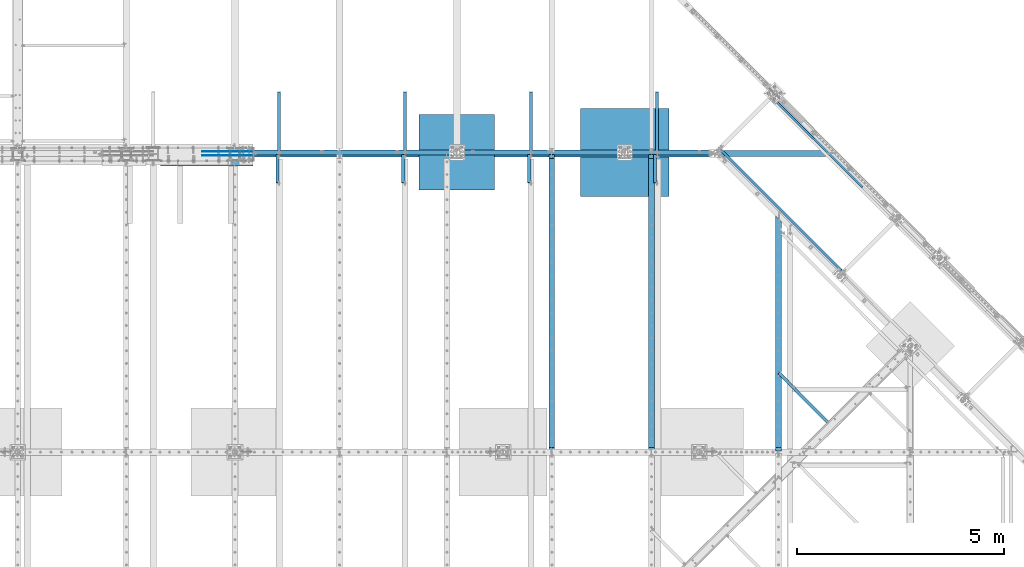
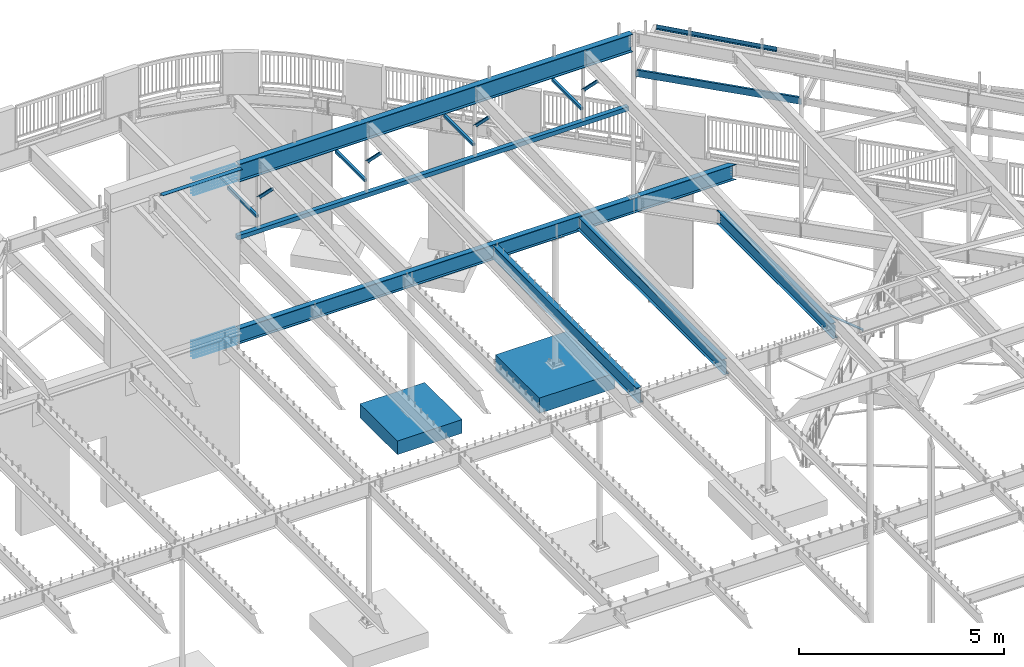
# One storey, part 326 of 975: 37 beams, 4 members.
"""IFC2X3 building model written with IfcOpenShell, lengths in millimetres."""

from ifc_helpers import new_model, si_unit, frame, origin_with_axes, place, context, subcontext, project, spatial, faceted_brep, material, type_object, element, save


model = new_model("IFC2X3")

# Units and contexts
model_context = context("Model", 3, precision=1e-05, world=origin_with_axes())
body_context = subcontext(model_context, "Body", "Model", "MODEL_VIEW")
ifc_project = project(units=[si_unit("LENGTHUNIT", "METRE", prefix="MILLI"), si_unit("AREAUNIT", "SQUARE_METRE"), si_unit("VOLUMEUNIT", "CUBIC_METRE"), si_unit("MASSUNIT", "GRAM", prefix="KILO"), si_unit("TIMEUNIT", "SECOND"), si_unit("PLANEANGLEUNIT", "RADIAN"), si_unit("SOLIDANGLEUNIT", "STERADIAN"), si_unit("THERMODYNAMICTEMPERATUREUNIT", "DEGREE_CELSIUS"), si_unit("LUMINOUSINTENSITYUNIT", "LUMEN")], contexts=[model_context])

# Site, building, storey
site_placement = place(None, origin_with_axes())
site = spatial("IfcSite", under=ifc_project, at=site_placement, CompositionType="ELEMENT")
building_placement = place(site_placement, origin_with_axes())
building = spatial("IfcBuilding", under=site, at=building_placement, Name="Undefined", CompositionType="ELEMENT")
storey_placement = place(building_placement, origin_with_axes())
storey = spatial("IfcBuildingStorey", under=building, at=storey_placement, Name="Undefined", CompositionType="ELEMENT", Elevation=0.0)

# Beams
ifc_material_1 = material(Name="STEEL/A36")
beam_type_1 = type_object("IfcBeamType", Name="L3X3X3/16", PredefinedType="NOTDEFINED")
beam_1_placement = place(storey_placement, frame((26609.1095943262, 15351.2595694684, 3500.82319096542), z_axis=(-0.709201369085879, -0.705005970248986, -3.88708940590731e-11), x_axis=(0.668493859661908, -0.672471979659895, -0.317643504839351)))
element("IfcBeam", 1, at=beam_1_placement, inside=storey, type_object=beam_type_1, material=ifc_material_1, Name="ANGLE", ObjectType="L3X3X3/16", context=body_context, shape_type="Brep", body=[
    faceted_brep([(1805.75505965487, -38.0999848286856, -33.3375000011256), (1805.7550483363, -38.0999874451672, -38.1000000011118), (1805.75504779872, 33.3375083154024, -38.1000000009481), (1805.75505910126, 33.3375121047993, -33.33750000082), (1825.84512851132, -26.6347548695767, -38.1000000010317), (1825.84531068586, -26.6346938414199, -33.3375000011692), (1830.36134276969, -25.1218538821231, 38.0999999983069), (1825.84531068138, -26.6346938276884, 38.0999999987871), (1830.36116117237, -25.1219147321481, -38.1000000011736), (49.1111607979174, -38.0999996707915, -33.3375000000524), (49.1111494785901, -38.0999996707933, -38.1000000000531), (1754.34679386706, -38.0999882398091, -38.1000000008753), (1754.34679386708, -38.0999882398073, -33.3375000008782), (49.1111489563682, 38.1000003292011, -38.0999999999622), (49.1111603083318, 33.3375003292022, -33.3374999999724), (49.1113300982161, 33.3375003292231, 38.0999999999876), (49.1113300655752, 38.100000329222, 38.0999999999949), (1809.18227678388, 38.100012127793, 38.0999999991473), (1809.18227678352, 38.100012127773, -38.1000000008098), (1805.75505910161, 33.3375121048202, 38.0999999991363)], [[[0, 1, 2, 3]], [[3, 2, 4, 5]], [[6, 7, 5, 4, 8]], [[9, 10, 11, 12]], [[13, 10, 9, 14, 15, 16]], [[13, 16, 17, 18]], [[18, 17, 6, 8]], [[2, 1, 11, 10, 13, 18, 8, 4]], [[12, 11, 1, 0]], [[14, 9, 12, 0, 3]], [[15, 14, 3, 19]], [[19, 3, 5, 7]], [[17, 16, 15, 19, 7, 6]]]),
])
beam_type_2 = type_object("IfcBeamType", Name="C8X11.5", PredefinedType="NOTDEFINED")
beam_2_placement = place(storey_placement, frame((25217.6926586422, 20740.4198954888, 7518.41643900487), z_axis=(-0.0127173168834997, 0.0127218758834606, -0.999838198772827), x_axis=(0.706865667090082, -0.707119051090114, -0.0179882260022924)))
element("IfcBeam", 2, at=beam_2_placement, inside=storey, type_object=beam_type_2, material=ifc_material_1, Name="BEAM", ObjectType="C8X11.5", context=body_context, shape_type="Brep", body=[
    faceted_brep([(25.0273563885617, 22.2249999999331, -76.2000000000671), (25.035636834773, 28.5749999999243, -76.2000000000744), (49.9041381300881, 28.5749999999498, -76.1999999999989), (49.9041381300995, 22.2249999999585, -76.2000000000016), (54.7642176481299, 28.5749999999571, -77.1667299225792), (54.7642176481413, 22.2249999999585, -77.166729922581), (58.8843941162781, 28.5749999999607, -79.9197438230522), (58.8843941162891, 22.2249999999622, -79.9197438230531), (61.6374080167493, 28.5749999999534, -84.0399202912031), (61.637408016762, 22.2249999999622, -84.0399202912049), (62.6041379393469, 19.0576241938725, -88.8999998092504), (62.6041379393328, 28.5749999999534, -88.8999998092477), (62.6041379393218, 28.5749999999425, -101.599999999954), (62.6041379393819, -28.5750000000044, -101.599999999935), (62.6041379393869, -28.5750000000007, -96.8355949999368), (62.4991749046949, 22.2249999999549, -88.3723149999569), (4164.10940048445, -28.5749999955915, -96.8355949983479), (4164.10940048445, -28.5749999955951, -101.599999998347), (4164.10940048439, 28.5750000043518, -101.599999998366), (4164.10940048435, 28.5750000043627, -88.8999998015706), (4164.10940048437, 19.0576242348288, -88.8999998015724), (28.2344609917245, 28.575000000099, 101.599999999969), (28.1599369758496, -28.5749999998516, 101.599999999989), (4214.8435793051, -28.5749999953478, 101.600000001609), (4214.90940048472, 28.5750000045955, 101.600000001591), (28.0742199128135, -28.5749999998552, 96.8355949999905), (4214.75786224206, -28.5749999953514, 96.8355950016112), (27.9881994526113, 22.2250000000859, 88.3723149999751), (4214.66410592741, 22.2250000045897, 88.3723150015967), (4211.70326286347, 22.2250000044332, -76.1999999922791), (4211.71057632787, 28.5750000044281, -76.1999999922855), (4176.80940029361, 22.2250000043896, -76.1999999923137), (4176.8094002936, 28.5750000043881, -76.1999999923128), (4171.94932077558, 22.2250000043859, -77.1667299149076), (4171.94932077557, 28.5750000043809, -77.1667299149067), (4167.82914430743, 22.2250000043787, -79.919743815386), (4167.82914430742, 28.5750000043736, -79.9197438153842), (4165.07613040695, 22.225000004375, -84.0399202835351), (4165.07613040694, 28.5750000043663, -84.0399202835333), (4164.21436351786, 22.2250000043678, -88.3723149983689)], [[[0, 1, 2, 3]], [[3, 2, 4, 5]], [[5, 4, 6, 7]], [[7, 6, 8, 9]], [[10, 11, 12, 13, 14]], [[15, 9, 8, 11, 10]], [[16, 17, 18, 19, 20]], [[21, 22, 23, 24]], [[22, 25, 26, 23]], [[25, 27, 28, 26]], [[24, 23, 26, 28, 29, 30]], [[29, 31, 32, 30]], [[33, 34, 32, 31]], [[35, 36, 34, 33]], [[37, 38, 36, 35]], [[39, 20, 19, 38, 37]], [[14, 16, 20, 39, 15, 10]], [[17, 16, 14, 13]], [[18, 17, 13, 12]], [[6, 4, 2, 1, 21, 24, 30, 32, 34, 36, 38, 19, 18, 12, 11, 8]], [[27, 25, 22, 21, 1, 0]], [[39, 37, 35, 33, 31, 29, 28, 27, 0, 3, 5, 7, 9, 15]]]),
])
beam_type_3 = type_object("IfcBeamType", PredefinedType="NOTDEFINED")
beam_3_placement = place(storey_placement, frame((27578.1189529659, 20861.2740185157, 7561.50945801746), z_axis=(0.707357212670032, -0.705780872372475, -0.0389760680011505), x_axis=(0.706317571755026, 0.707895110754471, 0.0)))
element("IfcBeam", 3, at=beam_3_placement, inside=storey, type_object=beam_type_3, material=ifc_material_1, Name="DECK_EDGE", context=body_context, shape_type="Brep", body=[
    faceted_brep([(-1.44573277793825e-08, -3.17500000027667, -1523.99999999641), (7.79618858359754e-09, -3.17499999972461, 1523.99999999641), (1.44573277793825e-08, 3.17500000027576, 1523.99999999641), (-7.79255060479045e-09, 3.17499999972188, -1523.9999999964), (51.3282235099323, 3.17500000138443, 1523.99999999883), (51.3282235078514, 3.17500000009932, -1523.99999999884), (57.6782232685582, -3.17499999981101, -1523.99999999882), (57.6782232706391, -3.17499999852589, 1523.99999999885), (51.3282275774545, 111.125003231497, 1523.99999999851), (51.3282275765887, 111.125003228997, -1523.99999999916), (57.6782275774676, 111.125002992181, 1523.99999999851), (57.6782275766018, 111.125002989683, -1523.99999999917)], [[[0, 1, 2, 3]], [[3, 2, 4, 5]], [[1, 0, 6, 7]], [[5, 4, 8, 9]], [[4, 2, 1, 7, 10, 8]], [[7, 6, 11, 10]], [[6, 0, 3, 5, 9, 11]], [[10, 11, 9, 8]]]),
])

# Members
member_type = type_object("IfcMemberType", Name="L3X3X3/8", PredefinedType="NOTDEFINED")
for number, where, z_axis, x_axis, name in (
    (4, (23658.5125015259, 19845.7293456865, 8357.14081169942), (0.0, -0.707106781186538, -0.707106781186557), (0.0, 0.707106781186529, -0.707106781186566), "ANGLE"),
    (5, (20610.5125015259, 19845.7293456865, 8357.14081169942), (0.0, -0.707106781186538, -0.707106781186557), (0.0, 0.707106781186529, -0.707106781186566), "ANGLE"),
    (6, (17562.5125015259, 19845.7293456865, 8357.14081169942), (0.0, -0.707106781186538, -0.707106781186557), (0.0, 0.707106781186529, -0.707106781186566), "ANGLE"),
    (7, (14514.5125015259, 19845.7293458214, 8357.14081183843), (0.0, -0.707106781186538, -0.707106781186557), (0.0, 0.707106781186529, -0.707106781186566), "ANGLE"),
):
    element("IfcMember", number, at=place(storey_placement, frame(where, z_axis=z_axis, x_axis=x_axis)), inside=storey, type_object=member_type, material=ifc_material_1, Name=name, ObjectType="L3X3X3/8", context=body_context, shape_type="Brep", body=[
        faceted_brep([(58.1980091705109, 38.0999999999985, -38.0999999999949), (58.1980092243903, 38.0999999999985, 38.1000000000204), (1023.10542864106, 38.0999999999985, 38.1000000003223), (1023.10542858717, 38.0999999999985, -38.0999999996893), (58.1980092243903, 28.5750000000007, 38.1000000000204), (1023.10542864106, 28.5750000000007, 38.1000000003223), (58.1980091772448, 28.5750000000007, -28.5749999999935), (1023.10542859391, 28.5750000000007, -28.5749999996879), (58.1980091772448, -38.0999999999985, -28.5749999999935), (1023.10542859391, -38.0999999999985, -28.5749999996879), (58.1980091705109, -38.0999999999985, -38.0999999999949), (1023.10542858717, -38.0999999999985, -38.0999999996893)], [[[0, 1, 2, 3]], [[1, 4, 5, 2]], [[4, 6, 7, 5]], [[6, 8, 9, 7]], [[8, 10, 11, 9]], [[10, 0, 3, 11]], [[5, 7, 9, 11, 3, 2]], [[10, 8, 6, 4, 1, 0]]]),
    ])

# Beams
beam_type_4 = type_object("IfcBeamType", Name="L5X3X5/16", PredefinedType="NOTDEFINED")
beam_4_placement = place(storey_placement, frame((11687.1750001999, 20380.3249929427, 8801.1), z_axis=(0.0, -1.0, 0.0), x_axis=(1.0, 0.0, 0.0)))
element("IfcBeam", 8, at=beam_4_placement, inside=storey, type_object=beam_type_4, material=ifc_material_1, Name="LEDGER_ANGLE", ObjectType="L5X3X5/16", context=body_context, shape_type="Brep", body=[
    faceted_brep([(5.0931703299284e-11, 38.0999999999999, -63.5000000000255), (-4.72937244921923e-11, 38.0999999999999, 63.5000000000182), (2241.54999999997, 38.1000000000004, 63.4999999970132), (2241.55000000003, 38.1000000000004, -63.5000000029868), (-3.63797880709171e-12, 30.1625000000404, 63.4999999999909), (2241.54999999997, 30.1625000000004, 63.4999999970132), (3.41060513164848e-12, 30.1624999999367, -55.5625000000091), (2241.55000000003, 30.1625000000004, -55.5625000029868), (2.27373675443232e-12, -38.1000000000313, -55.5624999999873), (2241.55000000003, -38.1000000000004, -55.5625000029868), (5.0931703299284e-11, -38.0999999999999, -63.5000000000255), (2241.55000000003, -38.1000000000004, -63.5000000029868)], [[[0, 1, 2, 3]], [[1, 4, 5, 2]], [[4, 6, 7, 5]], [[6, 8, 9, 7]], [[8, 10, 11, 9]], [[10, 0, 3, 11]], [[5, 7, 9, 11, 3, 2]], [[10, 8, 6, 4, 1, 0]]]),
])
ifc_material_2 = material(Name="STEEL/A496")
beam_type_5 = type_object("IfcBeamType", Name="#6 DBA", PredefinedType="NOTDEFINED")
for number, where, z_axis, x_axis, name in (
    (9, (13909.6749905832, 20570.8250016075, 8618.54742537138), (0.0, 1.0, 0.0), (-0.999999999999998, 6.90000001668524e-08, 0.0), "ROD"),
    (10, (13909.6749909893, 20672.4250015897, 8529.64743747955), (0.0, 1.0, 0.0), (-0.999999999999998, 6.90000001668524e-08, 0.0), "ROD"),
    (11, (13909.6749905832, 20570.8250015897, 8529.64743749572), (0.0, 1.0, 0.0), (-0.999999999999998, 6.90000001668524e-08, 0.0), "ROD"),
    (12, (13909.6749909893, 20672.4250015719, 8440.74744960389), (0.0, 1.0, 0.0), (-0.999999999999998, 6.90000001668524e-08, 0.0), "ROD"),
    (13, (13909.6749905832, 20570.8250015719, 8440.74744962006), (0.0, 1.0, 0.0), (-0.999999999999998, 6.90000001668524e-08, 0.0), "ROD"),
    (14, (13909.6749909893, 20672.425001554, 8351.84746172823), (0.0, 1.0, 0.0), (-0.999999999999998, 6.90000001668524e-08, 0.0), "ROD"),
    (15, (13909.6749905832, 20570.825001554, 8351.8474617444), (0.0, 1.0, 0.0), (-0.999999999999998, 6.90000001668524e-08, 0.0), "ROD"),
    (16, (13909.6749909893, 20672.4250016431, 8796.34740110652), (0.0, 1.0, 0.0), (-0.999999999999998, 6.90000001668524e-08, 0.0), "ROD"),
    (17, (13909.6749905832, 20570.8250016431, 8796.34740112269), (0.0, 1.0, 0.0), (-0.999999999999998, 6.90000001668524e-08, 0.0), "ROD"),
    (18, (13909.675, 20672.5350997173, 3849.6875), (0.0, 1.0, 0.0), (-0.999999999999998, 6.90000001668524e-08, 0.0), "ROD"),
    (19, (13909.675, 20570.9350997173, 3849.6875), (0.0, 1.0, 0.0), (-0.999999999999998, 6.90000001668524e-08, 0.0), "ROD"),
    (20, (13909.675, 20672.5350997173, 3760.7875), (0.0, 1.0, 0.0), (-0.999999999999998, 6.90000001668524e-08, 0.0), "ROD"),
    (21, (13909.675, 20570.9350997173, 3760.7875), (0.0, 1.0, 0.0), (-0.999999999999998, 6.90000001668524e-08, 0.0), "ROD"),
    (22, (13909.675, 20672.5350997173, 3671.8875), (0.0, 1.0, 0.0), (-0.999999999999998, 6.90000001668524e-08, 0.0), "ROD"),
    (23, (13909.675, 20570.9350997173, 3671.8875), (0.0, 1.0, 0.0), (-0.999999999999998, 6.90000001668524e-08, 0.0), "ROD"),
    (24, (13909.675, 20672.5350997173, 3582.9875), (0.0, 1.0, 0.0), (-0.999999999999998, 6.90000001668524e-08, 0.0), "ROD"),
    (25, (13909.675, 20570.9350997173, 3582.9875), (0.0, 1.0, 0.0), (-0.999999999999998, 6.90000001668524e-08, 0.0), "ROD"),
    (26, (13909.675, 20672.5350997173, 3494.0875), (0.0, 1.0, 0.0), (-0.999999999999998, 6.90000001668524e-08, 0.0), "ROD"),
    (27, (13909.675, 20570.9350997173, 3494.0875), (0.0, 1.0, 0.0), (-0.999999999999998, 6.90000001668524e-08, 0.0), "ROD"),
    (28, (13909.675, 20672.5350997173, 3938.5875), (0.0, 1.0, 0.0), (-0.999999999999998, 6.90000001668524e-08, 0.0), "ROD"),
    (29, (13909.675, 20570.9350997173, 3938.5875), (0.0, 1.0, 0.0), (-0.999999999999998, 6.90000001668524e-08, 0.0), "ROD"),
):
    element("IfcBeam", number, at=place(storey_placement, frame(where, z_axis=z_axis, x_axis=x_axis)), inside=storey, type_object=beam_type_5, material=ifc_material_2, Name=name, ObjectType="#6 DBA", context=body_context, shape_type="Brep", body=[
        faceted_brep([(0.0, -6.34999999998763, -3.63797880709171e-12), (0.0, -4.49012806052269, -4.49012806054634), (1219.19983372321, -4.49012806053543, -4.49012805836537), (1219.19983372321, -6.35000000000036, 2.16823536902666e-09), (0.0, 7.27595761418343e-12, -6.35000000000764), (1219.19983372321, 0.0, -6.34999999783395), (0.0, 4.49012806053724, -4.49012806053906), (1219.19983372321, 4.49012806053543, -4.49012805836537), (0.0, 6.34999999999491, 5.45696821063757e-12), (1219.19983372321, 6.35000000000036, 2.16823536902666e-09), (0.0, 4.49012806052633, 4.49012806054634), (1219.19983372321, 4.49012806053543, 4.49012806270184), (0.0, 0.0, 6.35000000000764), (1219.19983372321, 0.0, 6.35000000216678), (0.0, -4.49012806053361, 4.49012806053543), (1219.19983372321, -4.49012806053543, 4.49012806270184)], [[[0, 1, 2, 3]], [[1, 4, 5, 2]], [[4, 6, 7, 5]], [[6, 8, 9, 7]], [[8, 10, 11, 9]], [[10, 12, 13, 11]], [[12, 14, 15, 13]], [[14, 0, 3, 15]], [[5, 7, 9, 11, 13, 15, 3, 2]], [[14, 12, 10, 8, 6, 4, 1, 0]]]),
    ])
ifc_material_3 = material()
beam_type_6 = type_object("IfcBeamType", Name="HSS5X5X3/8", PredefinedType="NOTDEFINED")
beam_5_placement = place(storey_placement, frame((13928.725, 20646.9149014879, 6623.05), z_axis=(0.0, 0.0, -1.0), x_axis=(1.0, 0.0, 0.0)))
element("IfcBeam", 30, at=beam_5_placement, inside=storey, type_object=beam_type_6, material=ifc_material_3, Name="FRAME", ObjectType="HSS5X5X3/8", context=body_context, shape_type="Brep", body=[
    faceted_brep([(19.0499999999975, 53.9749999999985, -53.9750000000004), (19.0499999999975, -53.9749999999985, -53.9750000000004), (11028.4222488598, -53.9749999999985, -53.9750000000004), (11028.4222488598, 53.9749999999985, -53.9750000000004), (19.0499999999975, -53.9749999999985, 53.9750000000004), (11028.4222488598, -53.9749999999985, 53.9750000000004), (19.0499999999975, 53.9749999999985, 53.9750000000004), (11028.4222488598, 53.9749999999985, 53.9750000000004), (19.0499999999975, 63.5, -63.5), (19.0499999999975, 63.5, 63.5), (11028.4222488598, 63.5, 63.5), (11028.4222488598, 63.5, -63.5), (19.0499999999975, -63.5, 63.5), (11028.4222488598, -63.5, 63.5), (19.0499999999975, -63.5, -63.5), (11028.4222488598, -63.5, -63.5)], [[[0, 1, 2, 3]], [[1, 4, 5, 2]], [[4, 6, 7, 5]], [[6, 0, 3, 7]], [[8, 9, 10, 11]], [[9, 12, 13, 10]], [[12, 14, 15, 13]], [[14, 8, 11, 15]], [[13, 15, 11, 10], [5, 7, 3, 2]], [[14, 12, 9, 8], [6, 4, 1, 0]]]),
])
ifc_material_4 = material(Name="STEEL/A992")
beam_type_7 = type_object("IfcBeamType", Name="W18X40", PredefinedType="NOTDEFINED")
beam_6_placement = place(storey_placement, frame((13928.725, 20621.7350997173, 3709.9875), z_axis=(0.0, 0.0, 1.0), x_axis=(1.0, 0.0, 0.0)))
element("IfcBeam", 31, at=beam_6_placement, inside=storey, type_object=beam_type_7, material=ifc_material_4, Name="BEAM", ObjectType="W18X40", context=body_context, shape_type="Brep", body=[
    faceted_brep([(25.3999999999992, -76.1999999999998, -214.3125), (25.3999999999996, -76.2000000000007, -227.0125), (14043.6465678821, -76.2000000000007, -227.0125), (14043.6465678821, -76.2000000000007, -214.3125), (25.3999999999992, -3.96875, -214.3125), (13971.4153178821, -3.96875, -214.3125), (25.3999999999992, -3.96875, 214.312499999999), (13971.4153178821, -3.96875, 214.3125), (25.3999999999992, -76.1999999999998, 214.312499999999), (14043.6465678821, -76.2000000000007, 214.3125), (25.3999999999996, -76.2000000000007, 227.0125), (14043.6465678821, -76.2000000000007, 227.0125), (25.3999999999996, 76.2000000000007, 227.0125), (13891.2465678821, 76.2000000000007, 227.0125), (25.3999999999992, 76.1999999999998, 214.312499999999), (13891.2465678821, 76.2000000000007, 214.3125), (25.3999999999992, 3.96875, 214.312499999999), (13963.4778178821, 3.96875, 214.3125), (25.3999999999992, 3.96875, -214.3125), (13963.4778178821, 3.96875, -214.3125), (25.3999999999992, 76.1999999999998, -214.3125), (13891.2465678821, 76.2000000000007, -214.3125), (25.3999999999996, 76.2000000000007, -227.0125), (13891.2465678821, 76.2000000000007, -227.0125)], [[[0, 1, 2, 3]], [[4, 0, 3, 5]], [[6, 4, 5, 7]], [[8, 6, 7, 9]], [[10, 8, 9, 11]], [[12, 10, 11, 13]], [[14, 12, 13, 15]], [[16, 14, 15, 17]], [[18, 16, 17, 19]], [[20, 18, 19, 21]], [[1, 0, 4, 6, 8, 10, 12, 14, 16, 18, 20, 22]], [[1, 22, 23, 2]], [[19, 17, 15, 13, 11, 9, 7, 5, 3, 2, 23, 21]], [[22, 20, 21, 23]]]),
])
beam_type_8 = type_object("IfcBeamType", Name="HSS3X3X1/4", PredefinedType="NOTDEFINED")
for number, where, z_axis, x_axis in (
    (32, (23701.375, 20647.0249996575, 6997.7), (0.0, 0.0, -1.0), (0.0, 1.0, 0.0)),
    (33, (20653.375, 20647.025, 6997.7), (0.0, 0.0, -1.0), (0.0, 1.0, 0.0)),
    (34, (17605.375, 20647.025, 6997.7), (0.0, 0.0, -1.0), (0.0, 1.0, 0.0)),
    (35, (14557.375, 20646.9149014879, 6997.7), (0.0, 0.0, -1.0), (0.0, 1.0, 0.0)),
):
    element("IfcBeam", number, at=place(storey_placement, frame(where, z_axis=z_axis, x_axis=x_axis)), inside=storey, type_object=beam_type_8, material=ifc_material_3, ObjectType="HSS3X3X1/4", context=body_context, shape_type="Brep", body=[
        faceted_brep([(38.1000000984241, 31.75, -31.75), (38.1000000984241, -31.75, -31.75), (1466.84999999999, -31.75, -31.75), (1466.84999999999, 31.75, -31.75), (38.1000001619213, -31.75, 31.75), (1466.84999999999, -31.75, 31.75), (38.1000001619213, 31.75, 31.75), (1466.84999999999, 31.75, 31.75), (38.1000000920722, 38.0999999999985, -38.1000000000004), (38.1000001682733, 38.0999999999985, 38.1000000000004), (1466.84999999999, 38.1000000000004, 38.1000000000004), (1466.84999999999, 38.1000000000004, -38.1000000000004), (38.1000001682733, -38.0999999999985, 38.1000000000004), (1466.84999999999, -38.1000000000004, 38.1000000000004), (38.1000000920722, -38.0999999999985, -38.1000000000004), (1466.84999999999, -38.1000000000004, -38.1000000000004)], [[[0, 1, 2, 3]], [[1, 4, 5, 2]], [[4, 6, 7, 5]], [[6, 0, 3, 7]], [[8, 9, 10, 11]], [[9, 12, 13, 10]], [[12, 14, 15, 13]], [[14, 8, 11, 15]], [[13, 15, 11, 10], [5, 7, 3, 2]], [[14, 12, 9, 8], [6, 4, 1, 0]]]),
    ])
beam_type_9 = type_object("IfcBeamType", Name="W16X26", PredefinedType="NOTDEFINED")
beam_7_placement = place(storey_placement, frame((26644.6, 13392.15, 3736.975), z_axis=(0.0, 0.0, 1.0), x_axis=(0.0, 1.0, 0.0)))
element("IfcBeam", 36, at=beam_7_placement, inside=storey, type_object=beam_type_9, material=ifc_material_4, Name="BEAM", ObjectType="W16X26", context=body_context, shape_type="Brep", body=[
    faceted_brep([(105.568750190729, -3.17499999999927, 174.625), (105.568750190729, 3.17499999999927, 174.625), (29.368749999996, 3.17499999999927, 174.625), (29.368749999996, -3.17499999999927, 174.625), (110.428829708775, -3.17499999999927, 175.591729922588), (110.428829708775, 3.17499999999927, 175.591729922588), (114.549006176929, -3.17499999999927, 178.344743823066), (114.549006176929, 3.17499999999927, 178.344743823066), (117.302020077406, -3.17499999999927, 182.46492029122), (117.302020077406, 3.17499999999927, 182.46492029122), (118.268749999994, -3.17499999999927, 187.324999809266), (118.268749999994, 3.17499999999927, 187.324999809266), (118.268749999994, -69.8499999999985, 200.024999810586), (118.268749999994, 69.8499999999985, 200.025), (118.268749999994, 69.8499999999985, 190.5), (118.268749999994, 3.17499999999927, 190.5), (118.268749999994, -3.17499999999927, 190.5), (118.268749999994, -69.8499999999985, 190.5), (29.368749999996, -3.17499999999927, -190.5), (29.368749999996, -69.8499999999985, -190.5), (5582.0400360495, -69.8499999999985, -190.5), (5649.11146855339, -3.17499999999927, -190.5), (29.368749999996, -69.8499999999985, -200.025), (5582.0400360495, -69.8499999999985, -200.025), (29.368749999996, 69.8499999999985, -200.025), (5722.57065653385, 69.8499999999985, -200.025), (29.368749999996, 69.8499999999985, -190.5), (29.368749999996, 3.17499999999927, -190.5), (5655.49922402995, 3.17499999999927, -190.5), (5722.57065653385, 69.8499999999985, -190.5), (5655.49922402995, 3.17499999999927, 190.5), (5722.57065653385, 69.8499999999985, 190.5), (5722.57065653385, 69.8499999999985, 200.025), (5582.0400360495, -69.8499999999985, 200.025), (5582.0400360495, -69.8499999999985, 190.5), (5649.11146855339, -3.17499999999927, 190.5)], [[[0, 1, 2, 3]], [[4, 5, 1, 0]], [[6, 7, 5, 4]], [[8, 9, 7, 6]], [[10, 11, 9, 8]], [[12, 13, 14, 15, 11, 10, 16, 17]], [[18, 19, 20, 21]], [[19, 22, 23, 20]], [[22, 24, 25, 23]], [[26, 27, 28, 29]], [[24, 26, 29, 25]], [[28, 30, 31, 32, 33, 34, 35, 21, 20, 23, 25, 29]], [[34, 33, 12, 17]], [[35, 34, 17, 16]], [[8, 6, 4, 0, 3, 18, 21, 35, 16, 10]], [[27, 26, 24, 22, 19, 18, 3, 2]], [[30, 28, 27, 2, 1, 5, 7, 9, 11, 15]], [[31, 30, 15, 14]], [[32, 31, 14, 13]], [[33, 32, 13, 12]]]),
])
beam_8_placement = place(storey_placement, frame((23571.2, 13392.15, 3736.975), z_axis=(0.0, 0.0, 1.0), x_axis=(0.0, 1.0, 0.0)))
element("IfcBeam", 37, at=beam_8_placement, inside=storey, type_object=beam_type_9, material=ifc_material_4, Name="BEAM", ObjectType="W16X26", context=body_context, shape_type="Brep", body=[
    faceted_brep([(105.568750190729, -3.17499999999927, 174.625), (105.568750190729, 3.17499999999927, 174.625), (29.368749999996, 3.17499999999927, 174.625), (29.368749999996, -3.17499999999927, 174.625), (110.428829708775, -3.17499999999927, 175.591729922588), (110.428829708775, 3.17499999999927, 175.591729922588), (114.549006176929, -3.17499999999927, 178.344743823066), (114.549006176929, 3.17499999999927, 178.344743823066), (117.302020077406, -3.17499999999927, 182.46492029122), (117.302020077406, 3.17499999999927, 182.46492029122), (118.268749999994, -3.17499999999927, 187.324999809266), (118.268749999994, 3.17499999999927, 187.324999809266), (118.268749999994, -69.8499999999985, 200.024999810586), (118.268749999994, 69.8499999999985, 200.025), (118.268749999994, 69.8499999999985, 190.5), (118.268749999994, 3.17499999999927, 190.5), (118.268749999994, -3.17499999999927, 190.5), (118.268749999994, -69.8499999999985, 190.5), (29.368749999996, -3.17499999999927, -190.5), (29.368749999996, -69.8499999999985, -190.5), (7200.21634971727, -69.8499999999985, -190.5), (7200.21634971727, -3.17499999999927, -190.5), (29.368749999996, -69.8499999999985, -200.025), (7200.21634971727, -69.8499999999985, -200.025), (29.368749999996, 69.8499999999985, -200.025), (7200.21634971727, 69.8499999999985, -200.025), (29.368749999996, 69.8499999999985, -190.5), (7200.21634971727, 69.8499999999985, -190.5), (29.368749999996, 3.17499999999927, -190.5), (7200.21634971727, 3.17499999999927, -190.5), (7200.21634971727, 3.17499999999927, 174.625), (7200.21634971727, -3.17499999999927, 174.625), (7124.01634952653, 3.17499999999927, 174.625), (7124.01634952653, -3.17499999999927, 174.625), (7119.15627000848, 3.17499999999927, 175.591729922588), (7119.15627000848, -3.17499999999927, 175.591729922588), (7115.03609354033, 3.17499999999927, 178.344743823066), (7115.03609354033, -3.17499999999927, 178.344743823066), (7112.28307963985, 3.17499999999927, 182.464920291219), (7112.28307963985, -3.17499999999927, 182.464920291219), (7111.31634971726, 3.17499999999927, 187.324999809265), (7111.31634971726, -3.17499999999927, 187.324999809265), (7111.31634971726, -69.8499999999985, 200.025), (7111.31634971726, -69.8499999999985, 190.5), (7111.31634971726, -3.17499999999927, 190.5), (7111.31634971726, 3.17499999999927, 190.5), (7111.31634971726, 69.8499999999985, 190.5), (7111.31634971726, 69.8499999999985, 200.025)], [[[0, 1, 2, 3]], [[4, 5, 1, 0]], [[6, 7, 5, 4]], [[8, 9, 7, 6]], [[10, 11, 9, 8]], [[12, 13, 14, 15, 11, 10, 16, 17]], [[18, 19, 20, 21]], [[19, 22, 23, 20]], [[22, 24, 25, 23]], [[24, 26, 27, 25]], [[26, 28, 29, 27]], [[21, 20, 23, 25, 27, 29, 30, 31]], [[31, 30, 32, 33]], [[33, 32, 34, 35]], [[35, 34, 36, 37]], [[37, 36, 38, 39]], [[39, 38, 40, 41]], [[42, 43, 44, 41, 40, 45, 46, 47]], [[43, 42, 12, 17]], [[44, 43, 17, 16]], [[8, 6, 4, 0, 3, 18, 21, 31, 33, 35, 37, 39, 41, 44, 16, 10]], [[28, 26, 24, 22, 19, 18, 3, 2]], [[45, 40, 38, 36, 34, 32, 30, 29, 28, 2, 1, 5, 7, 9, 11, 15]], [[46, 45, 15, 14]], [[47, 46, 14, 13]], [[42, 47, 13, 12]]]),
])
beam_9_placement = place(storey_placement, frame((21158.2, 13392.15, 3736.975), z_axis=(0.0, 0.0, 1.0), x_axis=(0.0, 1.0, 0.0)))
element("IfcBeam", 38, at=beam_9_placement, inside=storey, type_object=beam_type_9, material=ifc_material_4, Name="BEAM", ObjectType="W16X26", context=body_context, shape_type="Brep", body=[
    faceted_brep([(105.568750190729, -3.17499999999927, 174.625), (105.568750190729, 3.17499999999927, 174.625), (29.368749999996, 3.17499999999927, 174.625), (29.368749999996, -3.17499999999927, 174.625), (110.428829708775, -3.17499999999927, 175.591729922588), (110.428829708775, 3.17499999999927, 175.591729922588), (114.549006176929, -3.17499999999927, 178.344743823066), (114.549006176929, 3.17499999999927, 178.344743823066), (117.302020077406, -3.17499999999927, 182.46492029122), (117.302020077406, 3.17499999999927, 182.46492029122), (118.268749999994, -3.17499999999927, 187.324999809266), (118.268749999994, 3.17499999999927, 187.324999809266), (118.268749999994, -69.8499999999985, 200.024999810586), (118.268749999994, 69.8499999999985, 200.025), (118.268749999994, 69.8499999999985, 190.5), (118.268749999994, 3.17499999999927, 190.5), (118.268749999994, -3.17499999999927, 190.5), (118.268749999994, -69.8499999999985, 190.5), (29.368749999996, -3.17499999999927, -190.5), (29.368749999996, -69.8499999999985, -190.5), (7200.21634971727, -69.8499999999985, -190.5), (7200.21634971727, -3.17499999999927, -190.5), (29.368749999996, -69.8499999999985, -200.025), (7200.21634971727, -69.8499999999985, -200.025), (29.368749999996, 69.8499999999985, -200.025), (7200.21634971727, 69.8499999999985, -200.025), (29.368749999996, 69.8499999999985, -190.5), (7200.21634971727, 69.8499999999985, -190.5), (29.368749999996, 3.17499999999927, -190.5), (7200.21634971727, 3.17499999999927, -190.5), (7200.21634971727, 3.17499999999927, 174.625), (7200.21634971727, -3.17499999999927, 174.625), (7124.01634952653, 3.17499999999927, 174.625), (7124.01634952653, -3.17499999999927, 174.625), (7119.15627000848, 3.17499999999927, 175.591729922588), (7119.15627000848, -3.17499999999927, 175.591729922588), (7115.03609354033, 3.17499999999927, 178.344743823066), (7115.03609354033, -3.17499999999927, 178.344743823066), (7112.28307963985, 3.17499999999927, 182.464920291219), (7112.28307963985, -3.17499999999927, 182.464920291219), (7111.31634971726, 3.17499999999927, 187.324999809265), (7111.31634971726, -3.17499999999927, 187.324999809265), (7111.31634971726, -69.8499999999985, 200.025), (7111.31634971726, -69.8499999999985, 190.5), (7111.31634971726, -3.17499999999927, 190.5), (7111.31634971726, 3.17499999999927, 190.5), (7111.31634971726, 69.8499999999985, 190.5), (7111.31634971726, 69.8499999999985, 200.025)], [[[0, 1, 2, 3]], [[4, 5, 1, 0]], [[6, 7, 5, 4]], [[8, 9, 7, 6]], [[10, 11, 9, 8]], [[12, 13, 14, 15, 11, 10, 16, 17]], [[18, 19, 20, 21]], [[19, 22, 23, 20]], [[22, 24, 25, 23]], [[24, 26, 27, 25]], [[26, 28, 29, 27]], [[21, 20, 23, 25, 27, 29, 30, 31]], [[31, 30, 32, 33]], [[33, 32, 34, 35]], [[35, 34, 36, 37]], [[37, 36, 38, 39]], [[39, 38, 40, 41]], [[42, 43, 44, 41, 40, 45, 46, 47]], [[43, 42, 12, 17]], [[44, 43, 17, 16]], [[8, 6, 4, 0, 3, 18, 21, 31, 33, 35, 37, 39, 41, 44, 16, 10]], [[28, 26, 24, 22, 19, 18, 3, 2]], [[45, 40, 38, 36, 34, 32, 30, 29, 28, 2, 1, 5, 7, 9, 11, 15]], [[46, 45, 15, 14]], [[47, 46, 14, 13]], [[42, 47, 13, 12]]]),
])
beam_type_10 = type_object("IfcBeamType", Name="W21X50", PredefinedType="NOTDEFINED")
beam_10_placement = place(storey_placement, frame((13941.425, 20621.625, 8574.0875), z_axis=(0.0, 0.0, 1.0), x_axis=(1.0, 0.0, 0.0)))
element("IfcBeam", 39, at=beam_10_placement, inside=storey, type_object=beam_type_10, material=ifc_material_4, Name="BEAM", ObjectType="W21X50", context=body_context, shape_type="Brep", body=[
    faceted_brep([(12.6999999999989, -82.5499999999993, -265.112499999999), (12.6999999999989, 82.5499999999993, -265.112499999999), (11103.4077443673, 82.5499999999993, -265.112499999999), (11103.4077443673, -82.5499999999993, -265.112499999999), (12.6999999999989, -82.5499999999993, -250.825000000001), (12.6999999999989, -4.76244999999835, -250.825000000001), (12.6999999999989, -4.76244999999835, 250.825000000001), (12.6999999999989, -82.5499999999993, 250.825000000001), (12.6999999999989, -82.5499999999993, 265.112499999999), (12.6999999999989, 82.5499999999993, 265.112499999999), (12.6999999999989, 82.5499999999993, 250.825000000001), (12.6999999999989, 4.76244999999835, 250.825000000001), (12.6999999999989, 4.76244999999835, -250.825000000001), (12.6999999999989, 82.5499999999993, -250.825000000001), (11103.4077443673, -82.5499999999993, -250.825000000001), (11103.4077443673, -4.76244999999835, -250.825000000001), (11103.4077443673, -4.76244999999835, 250.825000000001), (11103.4077443673, -82.5499999999993, 250.825000000001), (11103.4077443673, -82.5499999999993, 265.112499999999), (11103.4077443673, 82.5499999999993, 265.112499999999), (11103.4077443673, 82.5499999999993, 250.825000000001), (11103.4077443673, 4.76244999999835, 250.825000000001), (11103.4077443673, 4.76244999999835, -250.825000000001), (11103.4077443673, 82.5499999999993, -250.825000000001)], [[[0, 1, 2, 3]], [[0, 4, 5, 6, 7, 8, 9, 10, 11, 12, 13, 1]], [[5, 4, 14, 15]], [[6, 5, 15, 16]], [[7, 6, 16, 17]], [[8, 7, 17, 18]], [[9, 8, 18, 19]], [[10, 9, 19, 20]], [[11, 10, 20, 21]], [[12, 11, 21, 22]], [[13, 12, 22, 23]], [[1, 13, 23, 2]], [[22, 21, 20, 19, 18, 17, 16, 15, 14, 3, 2, 23]], [[4, 0, 3, 14]]]),
])
ifc_material_5 = material(Name="CONCRETE/5000")
beam_type_11 = type_object("IfcBeamType", PredefinedType="NOTDEFINED")
beam_11_placement = place(storey_placement, frame((21856.6999938965, 20647.025, -533.4), z_axis=(0.0, 0.0, 1.0), x_axis=(1.0, 0.0, 0.0)))
element("IfcBeam", 40, at=beam_11_placement, inside=storey, type_object=beam_type_11, material=ifc_material_5, Name="FOOTING", context=body_context, shape_type="Brep", body=[
    faceted_brep([(0.0, 1066.8, -228.6), (0.0, 1066.8, 228.6), (2133.6, 1066.8, 228.6), (2133.6, 1066.8, -228.6), (0.0, -1066.8, 228.6), (2133.6, -1066.8, 228.6), (0.0, -1066.8, -228.6), (2133.6, -1066.8, -228.6)], [[[0, 1, 2, 3]], [[1, 4, 5, 2]], [[4, 6, 7, 5]], [[6, 0, 3, 7]], [[5, 7, 3, 2]], [[6, 4, 1, 0]]]),
])
beam_type_12 = type_object("IfcBeamType", PredefinedType="NOTDEFINED")
beam_12_placement = place(storey_placement, frame((17945.1000084657, 20647.025023622, -508.0), z_axis=(0.0, 0.0, 1.0), x_axis=(1.0, 0.0, 0.0)))
element("IfcBeam", 41, at=beam_12_placement, inside=storey, type_object=beam_type_12, material=ifc_material_5, Name="FOOTING", context=body_context, shape_type="Brep", body=[
    faceted_brep([(0.0, 914.400000000001, -203.2), (0.0, 914.400000000001, 203.2), (1828.8, 914.400000000001, 203.2), (1828.8, 914.400000000001, -203.2), (0.0, -914.400000000001, 203.2), (1828.8, -914.400000000001, 203.2), (0.0, -914.400000000001, -203.2), (1828.8, -914.400000000001, -203.2)], [[[0, 1, 2, 3]], [[1, 4, 5, 2]], [[4, 6, 7, 5]], [[6, 0, 3, 7]], [[5, 7, 3, 2]], [[6, 4, 1, 0]]]),
])

save(model, "model.ifc")
